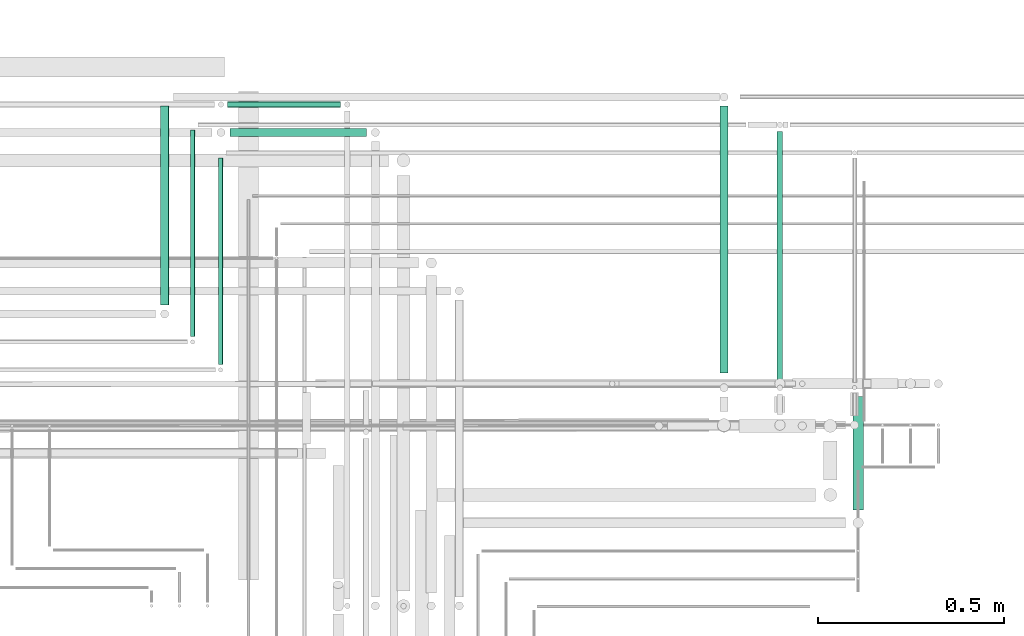
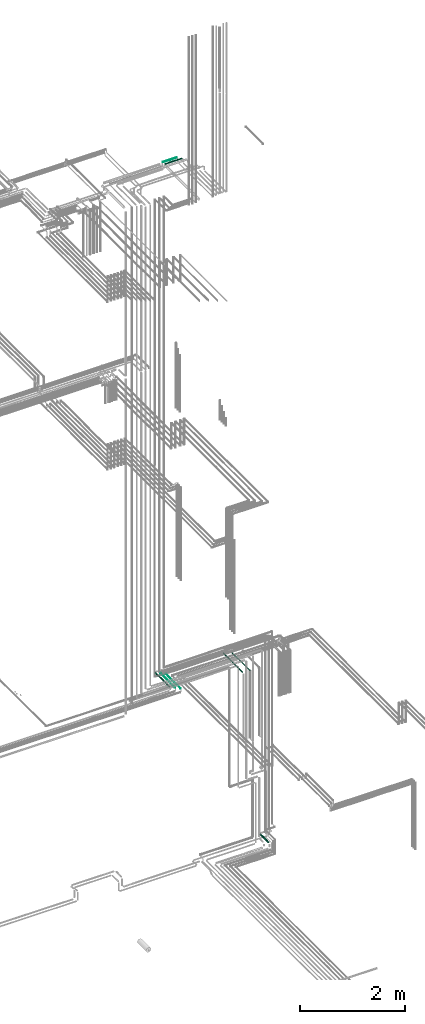
# One storey, part 234 of 331: 8 flow segments.
"""IFC2X3 building model written with IfcOpenShell, lengths in millimetres."""

from ifc_helpers import new_model, entity, si_unit, converted_unit, derived_unit, direction, frame, frame_2d, origin, origin_2d_with_axis, place, context, subcontext, project, spatial, circle, extrude, type_object, element, save


model = new_model("IFC2X3")

# Units and contexts
model_context = context("Model", 3, precision=0.01, world=origin(), true_north=direction((6.12303176911189e-17, 1.0)))
body_context = subcontext(model_context, "Body", "Model", "MODEL_VIEW")
ifc_project = project(units=[si_unit("LENGTHUNIT", "METRE", prefix="MILLI"), si_unit("AREAUNIT", "SQUARE_METRE"), si_unit("VOLUMEUNIT", "CUBIC_METRE"), converted_unit("PLANEANGLEUNIT", "DEGREE", entity("IfcRatioMeasure", 0.0174532925199433), si_unit("PLANEANGLEUNIT", "RADIAN"), dimensions=[0, 0, 0, 0, 0, 0, 0]), si_unit("MASSUNIT", "GRAM", prefix="KILO"), derived_unit("MASSDENSITYUNIT", [(si_unit("MASSUNIT", "GRAM", prefix="KILO"), 1), (si_unit("LENGTHUNIT", "METRE"), -3)]), derived_unit("MOMENTOFINERTIAUNIT", [(si_unit("LENGTHUNIT", "METRE"), 4)]), si_unit("TIMEUNIT", "SECOND"), si_unit("FREQUENCYUNIT", "HERTZ"), si_unit("THERMODYNAMICTEMPERATUREUNIT", "DEGREE_CELSIUS"), derived_unit("THERMALTRANSMITTANCEUNIT", [(si_unit("MASSUNIT", "GRAM", prefix="KILO"), 1), (si_unit("THERMODYNAMICTEMPERATUREUNIT", "KELVIN"), -1), (si_unit("TIMEUNIT", "SECOND"), -3)]), derived_unit("VOLUMETRICFLOWRATEUNIT", [(si_unit("LENGTHUNIT", "METRE"), 3), (si_unit("TIMEUNIT", "SECOND"), -1)]), derived_unit("MASSFLOWRATEUNIT", [(si_unit("MASSUNIT", "GRAM", prefix="KILO"), 1), (si_unit("TIMEUNIT", "SECOND"), -1)]), derived_unit("ROTATIONALFREQUENCYUNIT", [(si_unit("TIMEUNIT", "SECOND"), -1)]), si_unit("ELECTRICCURRENTUNIT", "AMPERE"), si_unit("ELECTRICVOLTAGEUNIT", "VOLT"), si_unit("POWERUNIT", "WATT"), si_unit("FORCEUNIT", "NEWTON", prefix="KILO"), si_unit("ILLUMINANCEUNIT", "LUX"), si_unit("LUMINOUSFLUXUNIT", "LUMEN"), si_unit("LUMINOUSINTENSITYUNIT", "CANDELA"), derived_unit("USERDEFINED", [(si_unit("MASSUNIT", "GRAM", prefix="KILO"), -1), (si_unit("LENGTHUNIT", "METRE"), -2), (si_unit("TIMEUNIT", "SECOND"), 3), (si_unit("LUMINOUSFLUXUNIT", "LUMEN"), 1)]), derived_unit("LINEARVELOCITYUNIT", [(si_unit("LENGTHUNIT", "METRE"), 1), (si_unit("TIMEUNIT", "SECOND"), -1)]), si_unit("PRESSUREUNIT", "PASCAL"), derived_unit("USERDEFINED", [(si_unit("LENGTHUNIT", "METRE"), -2), (si_unit("MASSUNIT", "GRAM", prefix="KILO"), 1), (si_unit("TIMEUNIT", "SECOND"), -2)]), derived_unit("LINEARFORCEUNIT", [(si_unit("MASSUNIT", "GRAM", prefix="KILO"), 1), (si_unit("LENGTHUNIT", "METRE"), 1), (si_unit("TIMEUNIT", "SECOND"), -2), (si_unit("LENGTHUNIT", "METRE"), -1)]), derived_unit("PLANARFORCEUNIT", [(si_unit("MASSUNIT", "GRAM", prefix="KILO"), 1), (si_unit("LENGTHUNIT", "METRE"), 1), (si_unit("TIMEUNIT", "SECOND"), -2), (si_unit("LENGTHUNIT", "METRE"), -2)])], contexts=[model_context])

# Site, building, storey
site_placement = place(None, frame((0.0, -0.00077364408347762, 0.0)))
site = spatial("IfcSite", under=ifc_project, at=site_placement, CompositionType="ELEMENT")
building_placement = place(site_placement, origin())
building = spatial("IfcBuilding", under=site, at=building_placement, CompositionType="ELEMENT")
storey_placement = place(building_placement, origin())
storey = spatial("IfcBuildingStorey", under=building, at=storey_placement, CompositionType="ELEMENT", Elevation=0.0)

# Flow segments
pipe_segment_type = type_object("IfcPipeSegmentType", PredefinedType="NOTDEFINED")
flow_segment_1_placement = place(building_placement, frame((66704.4020544242, 7921.93026688113, 2799.40472776409)))
element("IfcFlowSegment", 1, at=flow_segment_1_placement, inside=storey, type_object=pipe_segment_type, context=body_context, shape_type="SweptSolid", body=[
    extrude(circle(Radius=14.0, at=origin_2d_with_axis()), frame((15.5952722359214, 0.0, 15.595272235916), z_axis=(0.0, 1.0, 0.0), x_axis=(1.0, 0.0, 0.0)), (0.0, 0.0, 1.0), 305.070375513921),
])
flow_segment_2_placement = place(building_placement, frame((66501.0166110417, 8268.00064239501, 6665.90472776408)))
element("IfcFlowSegment", 2, at=flow_segment_2_placement, inside=storey, type_object=pipe_segment_type, context=body_context, shape_type="SweptSolid", body=[
    extrude(circle(Radius=7.5, at=origin_2d_with_axis()), frame((9.09527223591419, 0.0, 9.09527223591636), z_axis=(0.0, 1.0, 0.0), x_axis=(1.0, 0.0, 0.0)), (0.0, 0.0, 1.0), 668.998493957538),
])
flow_segment_3_placement = place(building_placement, frame((66347.5166110417, 8290.00064239503, 6662.40472776407)))
element("IfcFlowSegment", 3, at=flow_segment_3_placement, inside=storey, type_object=pipe_segment_type, context=body_context, shape_type="SweptSolid", body=[
    extrude(circle(Radius=11.0, at=frame_2d((0.0, 1.08286712929839e-12), x_axis=(1.0, 0.0))), frame((12.5952722359134, 0.0, 12.5952722359166), z_axis=(0.0, 1.0, 0.0), x_axis=(-1.0, 0.0, 0.0)), (0.0, 0.0, 1.0), 715.998493957538),
])
flow_segment_4_placement = place(storey_placement, frame((65035.1118832776, 8922.21546224628, 18547.4047277641)))
element("IfcFlowSegment", 4, at=flow_segment_4_placement, inside=storey, type_object=pipe_segment_type, context=body_context, shape_type="SweptSolid", body=[
    extrude(circle(Radius=11.0, at=frame_2d((0.0, -2.16573425859679e-12), x_axis=(1.0, 0.0))), frame((0.0, 12.5952722359156, 12.5952722359177), z_axis=(1.0, 0.0, 0.0), x_axis=(0.0, 1.0, 0.0)), (0.0, 0.0, 1.0), 366.000000000073),
])
flow_segment_5_placement = place(storey_placement, frame((65029.1118832776, 9000.71546224627, 18550.9047277641)))
element("IfcFlowSegment", 5, at=flow_segment_5_placement, inside=storey, type_object=pipe_segment_type, context=body_context, shape_type="SweptSolid", body=[
    extrude(circle(Radius=7.5, at=frame_2d((1.08286712929839e-12, 0.0), x_axis=(1.0, 0.0))), frame((0.0, 9.09527223591528, 9.09527223591636), z_axis=(1.0, 0.0, 0.0), x_axis=(0.0, 1.0, 0.0)), (0.0, 0.0, 1.0), 303.000000000078),
])
flow_segment_6_placement = place(storey_placement, frame((65002.5100168242, 8311.98770456779, 6742.40472776408)))
element("IfcFlowSegment", 6, at=flow_segment_6_placement, inside=storey, type_object=pipe_segment_type, context=body_context, shape_type="SweptSolid", body=[
    extrude(circle(Radius=6.0, at=frame_2d((0.0, -1.08286712929839e-12), x_axis=(1.0, 0.0))), frame((7.59527223591454, 0.0, 7.5952722359167), z_axis=(0.0, 1.0, 0.0), x_axis=(-1.0, 0.0, 0.0)), (0.0, 0.0, 1.0), 554.011431784775),
])
flow_segment_7_placement = place(storey_placement, frame((64927.5100168242, 8386.98770456777, 6742.40472776408)))
element("IfcFlowSegment", 7, at=flow_segment_7_placement, inside=storey, type_object=pipe_segment_type, context=body_context, shape_type="SweptSolid", body=[
    extrude(circle(Radius=6.0, at=origin_2d_with_axis()), frame((7.59527223591454, 0.0, 7.59527223591562), z_axis=(0.0, 1.0, 0.0), x_axis=(-1.0, 0.0, 0.0)), (0.0, 0.0, 1.0), 554.01143178479),
])
flow_segment_8_placement = place(storey_placement, frame((64847.5100168242, 8471.98770456778, 6737.40472776408)))
element("IfcFlowSegment", 8, at=flow_segment_8_placement, inside=storey, type_object=pipe_segment_type, context=body_context, shape_type="SweptSolid", body=[
    extrude(circle(Radius=11.0, at=frame_2d((8.66293703438714e-12, 0.0), x_axis=(1.0, 0.0))), frame((12.5952722359221, 0.0, 12.5952722359156), z_axis=(0.0, 1.0, 0.0), x_axis=(-1.0, 0.0, 0.0)), (0.0, 0.0, 1.0), 534.011431784787),
])

save(model, "model.ifc")
